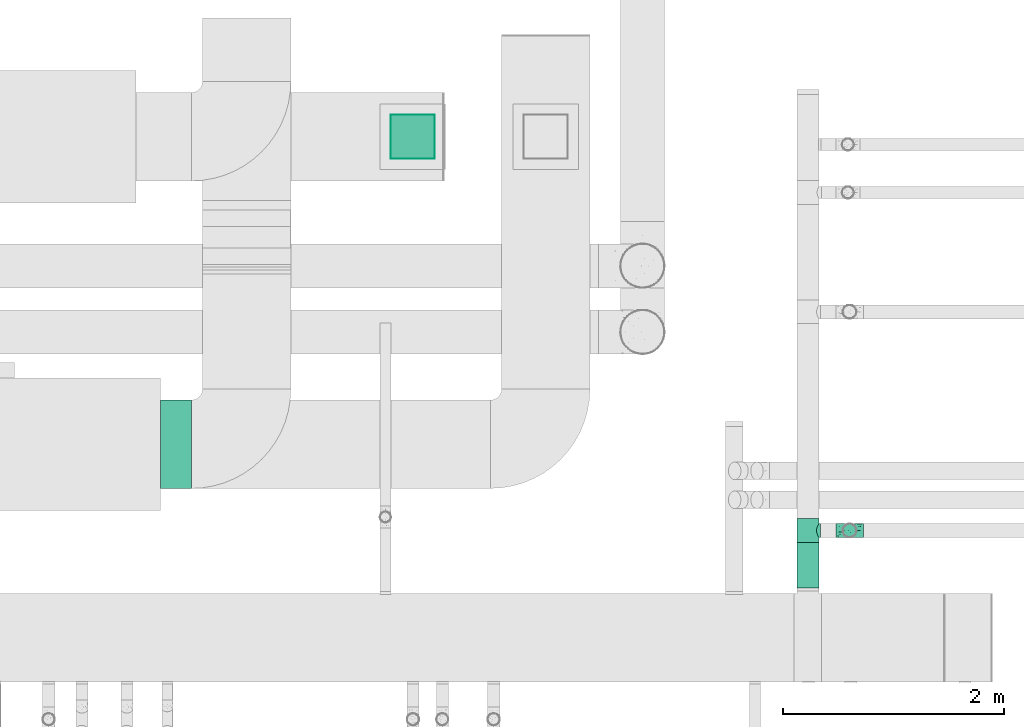
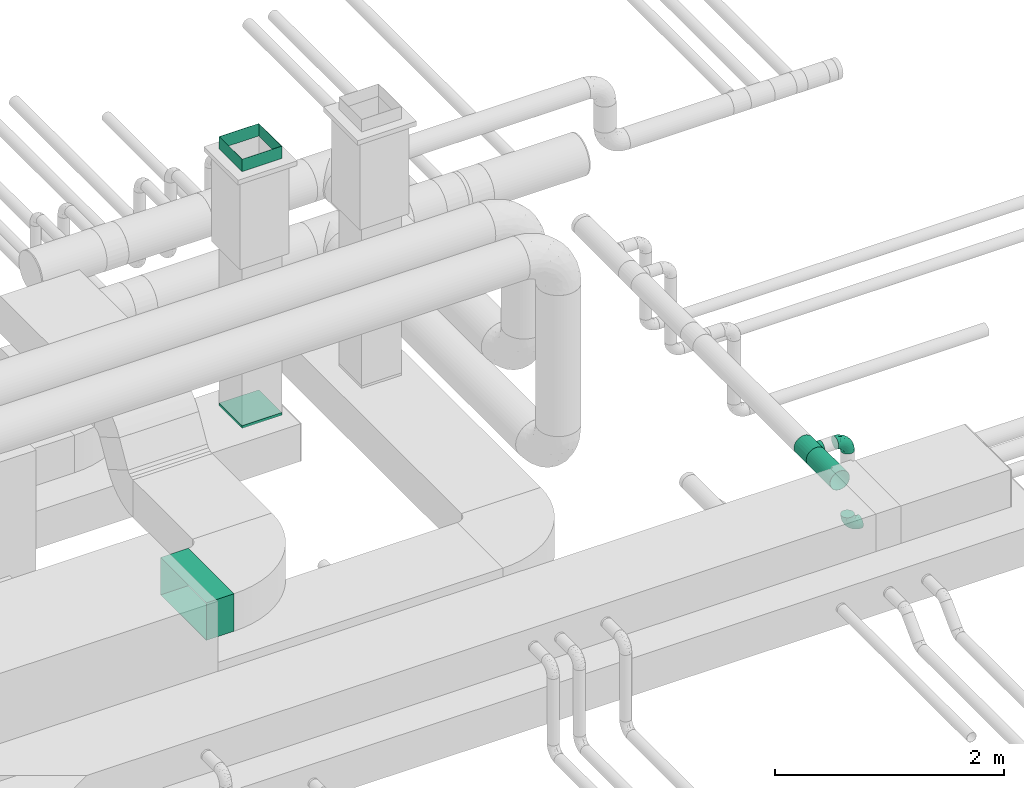
# One storey, part 63 of 91: 4 flow fittings, 3 flow segments.
"""IFC2X3 building model written with IfcOpenShell, lengths in millimetres."""

from ifc_helpers import new_model, entity, si_unit, converted_unit, derived_unit, direction, frame, origin_with_axes, origin_2d_with_axis, place, context, subcontext, project, spatial, hollow_rectangle, hollow_circle, extrude, open_shell, surface_model, source, transform, mapped, material, layer, layer_set, layer_usage, type_object, element, save


model = new_model("IFC2X3")

# Units and contexts
model_context = context("Model", 3, precision=1e-05, world=origin_with_axes(), true_north=direction((0.0, 1.0)))
body_context = subcontext(model_context, "Body", "Model", "MODEL_VIEW")
ifc_project = project(units=[si_unit("AREAUNIT", "SQUARE_METRE"), si_unit("VOLUMEUNIT", "CUBIC_METRE", prefix="DECI"), si_unit("TIMEUNIT", "SECOND"), si_unit("THERMODYNAMICTEMPERATUREUNIT", "DEGREE_CELSIUS"), si_unit("PRESSUREUNIT", "PASCAL"), si_unit("MASSUNIT", "GRAM", prefix="KILO"), si_unit("LENGTHUNIT", "METRE", prefix="MILLI"), si_unit("POWERUNIT", "WATT"), si_unit("ELECTRICCURRENTUNIT", "AMPERE"), si_unit("ELECTRICVOLTAGEUNIT", "VOLT"), derived_unit("VOLUMETRICFLOWRATEUNIT", [(si_unit("VOLUMEUNIT", "CUBIC_METRE", prefix="DECI"), 1), (si_unit("TIMEUNIT", "SECOND"), -1)]), derived_unit("LINEARVELOCITYUNIT", [(si_unit("LENGTHUNIT", "METRE"), 1), (si_unit("TIMEUNIT", "SECOND"), -1)]), derived_unit("MASSDENSITYUNIT", [(si_unit("MASSUNIT", "GRAM", prefix="KILO"), 1), (si_unit("VOLUMEUNIT", "CUBIC_METRE"), -1)]), converted_unit("PLANEANGLEUNIT", "DEGREE", entity("IfcRatioMeasure", 0.01745), si_unit("PLANEANGLEUNIT", "RADIAN"), dimensions=[0, 0, 0, 0, 0, 0, 0])], contexts=[model_context])

# Site, building, storey
site_placement = place(None, origin_with_axes())
site = spatial("IfcSite", under=ifc_project, at=site_placement, CompositionType="ELEMENT")
building_placement = place(site_placement, origin_with_axes())
building = spatial("IfcBuilding", under=site, at=building_placement, Name="mc-building", CompositionType="ELEMENT")
storey_placement = place(building_placement, frame((0.0, 0.0, 8700.0), z_axis=(0.0, 0.0, 1.0), x_axis=(1.0, 0.0, 0.0)))
storey = spatial("IfcBuildingStorey", under=building, at=storey_placement, CompositionType="ELEMENT", Elevation=8700.0)

# Flow fittings
duct_fitting_type_1 = type_object("IfcDuctFittingType", PredefinedType="JUNCTION")
shared_shape_1 = source(origin_with_axes(), body_context, "Body", "SurfaceModel", [
    surface_model("IfcShellBasedSurfaceModel", [(0.0, -115.0, -62.5), (16.17619, -115.0, -60.37037), (-16.17619, -115.0, -60.37037), (-60.37037, -115.0, 16.17619), (-31.25, -115.0, -54.12659), (-44.19417, -115.0, -44.19417), (-54.12659, -115.0, -31.25), (62.5, -115.0, 0.0), (60.37037, -115.0, 16.17619), (44.19417, -115.0, -44.19417), (31.25, -115.0, -54.12659), (60.37037, -115.0, -16.17619), (54.12659, -115.0, -31.25), (-60.37037, -115.0, -16.17619), (-54.12659, -115.0, 31.25), (-44.19417, -115.0, 44.19417), (-31.25, -115.0, 54.12659), (-16.17619, -115.0, 60.37037), (16.17619, -115.0, 60.37037), (54.12659, -115.0, 31.25), (44.19417, -115.0, 44.19417), (31.25, -115.0, 54.12659), (0.0, -115.0, 62.5), (-62.5, -115.0, 0.0), (0.0, -78.06248, 62.5), (-12.50928, -79.05841, 61.23535), (-24.28343, -81.75228, 57.58963), (-34.88436, -85.50245, 51.85876), (-44.09526, -89.65568, 44.29287), (-51.73336, -93.64876, 35.07007), (-57.55016, -96.98335, 24.37682), (-61.23402, -99.21368, 12.5158), (-62.5, -100.0, 0.0), (-61.23126, -99.21198, -12.5293), (-57.54468, -96.9801, -24.38976), (-51.72588, -93.64463, -35.0811), (-44.08702, -89.65163, -44.30107), (-34.87655, -85.49926, -51.86401), (-24.27625, -81.75015, -57.59265), (-12.50125, -79.05714, -61.23699), (0.0, -78.06248, -62.5), (12.50928, -79.05841, -61.23535), (24.28343, -81.75228, -57.58963), (34.88436, -85.50245, -51.85876), (44.09526, -89.65568, -44.29287), (51.73336, -93.64876, -35.07007), (57.55016, -96.98335, -24.37682), (61.23402, -99.21368, -12.5158), (62.5, -100.0, 0.0), (61.23402, -99.21368, 12.5158), (57.55016, -96.98335, 24.37682), (51.73336, -93.64876, 35.07007), (44.09526, -89.65568, 44.29287), (34.88436, -85.50245, 51.85876), (24.28343, -81.75228, 57.58963), (12.50928, -79.05841, 61.23535), (-107.5, 0.0, -100.0), (-107.5, -25.8819, -96.59259), (-107.5, 25.8819, -96.59259), (-107.5, 96.59259, 25.8819), (-107.5, 50.0, -86.60254), (-107.5, 86.60254, -50.0), (-107.5, 70.71068, -70.71068), (-107.5, -100.0, 0.0), (-107.5, -96.59259, 25.8819), (-107.5, -70.71068, -70.71068), (-107.5, -50.0, -86.60254), (-107.5, -96.59259, -25.8819), (-107.5, -86.60254, -50.0), (-107.5, 96.59259, -25.8819), (-107.5, 86.60254, 50.0), (-107.5, 70.71068, 70.71068), (-107.5, 50.0, 86.60254), (-107.5, 25.8819, 96.59259), (-107.5, 0.0, 100.0), (-107.5, -86.60254, 50.0), (-107.5, -70.71068, 70.71068), (-107.5, -25.8819, 96.59259), (-107.5, -50.0, 86.60254), (-107.5, 100.0, 0.0), (107.5, 25.8819, -96.59259), (107.5, 100.0, 0.0), (107.5, 0.0, -100.0), (107.5, 50.0, -86.60254), (107.5, 70.71068, -70.71068), (107.5, 86.60254, -50.0), (107.5, -70.71068, -70.71068), (107.5, -96.59259, 25.8819), (107.5, -50.0, -86.60254), (107.5, -25.8819, -96.59259), (107.5, -86.60254, -50.0), (107.5, -96.59259, -25.8819), (107.5, -100.0, 0.0), (107.5, 96.59259, -25.8819), (107.5, 96.59259, 25.8819), (107.5, 86.60254, 50.0), (107.5, 70.71068, 70.71068), (107.5, 25.8819, 96.59259), (107.5, 50.0, 86.60254), (107.5, -25.8819, 96.59259), (107.5, -86.60254, 50.0), (107.5, -70.71068, 70.71068), (107.5, -50.0, 86.60254), (107.5, 0.0, 100.0), (107.5, -91.59756, -37.94095), (-107.5, -98.29629, -12.94095), (-107.5, -91.59756, -37.94095), (107.5, -98.29629, -12.94095), (107.5, -98.29629, 12.94095), (107.5, -91.59756, 37.94095), (-107.5, -98.29629, 12.94095), (-107.5, -91.59756, 37.94095)], [open_shell([[[0, 1, 2]], [[2, 3, 4]], [[5, 3, 6]], [[4, 3, 5]], [[2, 7, 8]], [[9, 7, 10]], [[1, 10, 7]], [[11, 7, 12]], [[9, 12, 7]], [[7, 2, 1]], [[13, 6, 3]], [[2, 14, 3]], [[2, 15, 14]], [[16, 2, 17]], [[16, 15, 2]], [[17, 2, 18]], [[19, 20, 2]], [[19, 2, 8]], [[20, 21, 2]], [[2, 21, 18]], [[18, 22, 17]], [[23, 13, 3]], [[22, 24, 25]], [[17, 25, 26]], [[16, 26, 27]], [[22, 25, 17]], [[15, 27, 28]], [[16, 17, 26]], [[27, 15, 16]], [[29, 30, 14]], [[31, 32, 23]], [[30, 31, 3]], [[15, 29, 14]], [[3, 14, 30]], [[23, 3, 31]], [[29, 15, 28]], [[32, 33, 23]], [[34, 35, 6]], [[33, 34, 13]], [[23, 33, 13]], [[6, 13, 34]], [[5, 6, 35]], [[35, 36, 5]], [[4, 37, 38]], [[38, 39, 2]], [[40, 0, 39]], [[37, 5, 36]], [[37, 4, 5]], [[4, 38, 2]], [[39, 0, 2]], [[0, 40, 41]], [[1, 41, 42]], [[10, 42, 43]], [[0, 41, 1]], [[9, 43, 44]], [[10, 1, 42]], [[43, 9, 10]], [[45, 46, 12]], [[47, 48, 7]], [[46, 47, 11]], [[9, 45, 12]], [[11, 12, 46]], [[7, 11, 47]], [[45, 9, 44]], [[48, 49, 7]], [[50, 51, 19]], [[49, 50, 8]], [[7, 49, 8]], [[19, 8, 50]], [[20, 19, 51]], [[51, 52, 20]], [[21, 53, 54]], [[54, 55, 18]], [[24, 22, 55]], [[53, 20, 52]], [[53, 21, 20]], [[21, 54, 18]], [[55, 22, 18]], [[56, 57, 58]], [[58, 59, 60]], [[61, 62, 59]], [[59, 62, 60]], [[58, 63, 64]], [[65, 63, 66]], [[58, 57, 66]], [[67, 63, 68]], [[65, 68, 63]], [[66, 63, 58]], [[69, 61, 59]], [[70, 59, 58]], [[58, 71, 70]], [[72, 58, 73]], [[72, 71, 58]], [[74, 73, 58]], [[75, 76, 58]], [[58, 64, 75]], [[77, 74, 78]], [[58, 76, 78]], [[78, 74, 58]], [[79, 69, 59]], [[80, 81, 82]], [[83, 81, 80]], [[81, 84, 85]], [[83, 84, 81]], [[86, 82, 87]], [[82, 88, 89]], [[82, 86, 88]], [[90, 87, 91]], [[87, 90, 86]], [[92, 91, 87]], [[93, 81, 85]], [[94, 95, 82]], [[95, 96, 82]], [[97, 82, 98]], [[82, 96, 98]], [[99, 82, 97]], [[82, 100, 87]], [[101, 100, 82]], [[101, 82, 102]], [[99, 102, 82]], [[97, 103, 99]], [[82, 81, 94]], [[73, 103, 97]], [[72, 97, 98]], [[74, 103, 73]], [[73, 97, 72]], [[98, 71, 72]], [[98, 96, 71]], [[59, 95, 94]], [[79, 94, 81]], [[96, 70, 71]], [[96, 95, 70]], [[70, 95, 59]], [[94, 79, 59]], [[93, 85, 61]], [[81, 93, 69]], [[69, 79, 81]], [[61, 69, 93]], [[85, 62, 61]], [[85, 84, 62]], [[58, 83, 80]], [[56, 80, 82]], [[84, 60, 62]], [[84, 83, 60]], [[60, 83, 58]], [[80, 56, 58]], [[89, 57, 82]], [[88, 66, 89]], [[42, 90, 43]], [[90, 42, 86]], [[44, 104, 45]], [[42, 41, 86]], [[88, 86, 65]], [[86, 41, 40]], [[57, 89, 66]], [[65, 66, 88]], [[57, 56, 82]], [[40, 39, 65]], [[33, 63, 105]], [[65, 38, 68]], [[35, 67, 106]], [[46, 107, 47]], [[39, 38, 65]], [[65, 86, 40]], [[68, 38, 37]], [[104, 91, 45]], [[44, 90, 104]], [[91, 46, 45]], [[92, 48, 47]], [[91, 107, 46]], [[47, 107, 92]], [[35, 106, 36]], [[68, 36, 106]], [[35, 34, 67]], [[68, 37, 36]], [[105, 67, 34]], [[32, 63, 33]], [[105, 34, 33]], [[43, 90, 44]], [[48, 92, 49]], [[108, 87, 50]], [[50, 87, 51]], [[50, 49, 108]], [[52, 51, 109]], [[109, 100, 52]], [[63, 31, 110]], [[63, 32, 31]], [[30, 64, 110]], [[28, 75, 111]], [[111, 64, 29]], [[75, 28, 27]], [[29, 64, 30]], [[53, 100, 54]], [[51, 87, 109]], [[101, 55, 54]], [[54, 100, 101]], [[30, 110, 31]], [[102, 99, 77]], [[78, 101, 102]], [[55, 101, 24]], [[74, 99, 103]], [[25, 24, 76]], [[49, 92, 108]], [[26, 76, 75]], [[25, 76, 26]], [[28, 111, 29]], [[24, 101, 76]], [[101, 78, 76]], [[77, 78, 102]], [[99, 74, 77]], [[26, 75, 27]], [[53, 52, 100]]])]),
])
flow_fitting_1_placement = place(storey_placement, frame((33364.76981, 4322.30408, 1344.0), z_axis=(0.0, 0.0, 1.0), x_axis=(0.0, 1.0, 0.0)))
element("IfcFlowFitting", 1, at=flow_fitting_1_placement, inside=storey, type_object=duct_fitting_type_1, context=body_context, shape_type="MappedRepresentation", body=[
    mapped(shared_shape_1, transform((0.0, 0.0, 0.0), scale=1.0)),
])
duct_fitting_type_2 = type_object("IfcDuctFittingType", Name="BU", PredefinedType="BEND")
shared_shape_2 = source(origin_with_axes(), body_context, "Body", "SurfaceModel", [
    surface_model("IfcShellBasedSurfaceModel", [(-125.0, 0.0, -62.5), (-125.0, -16.17619, -60.37037), (-125.0, 16.17619, -60.37037), (-125.0, 60.37037, 16.17619), (-125.0, 31.25, -54.12659), (-125.0, 54.12659, -31.25), (-125.0, 44.19417, -44.19417), (-125.0, -62.5, 0.0), (-125.0, -60.37037, 16.17619), (-125.0, -44.19417, -44.19417), (-125.0, -31.25, -54.12659), (-125.0, -60.37037, -16.17619), (-125.0, -54.12659, -31.25), (-125.0, 60.37037, -16.17619), (-125.0, 54.12659, 31.25), (-125.0, 44.19417, 44.19417), (-125.0, 16.17619, 60.37037), (-125.0, 31.25, 54.12659), (-125.0, -16.17619, 60.37037), (-125.0, -54.12659, 31.25), (-125.0, -44.19417, 44.19417), (-125.0, -31.25, 54.12659), (-125.0, 0.0, 62.5), (-125.0, 62.5, 0.0), (-16.17619, 125.0, -60.37037), (-62.5, 125.0, 0.0), (0.0, 125.0, -62.5), (-31.25, 125.0, -54.12659), (-44.19417, 125.0, -44.19417), (-54.12659, 125.0, -31.25), (44.19417, 125.0, -44.19417), (60.37037, 125.0, 16.17619), (31.25, 125.0, -54.12659), (16.17619, 125.0, -60.37037), (54.12659, 125.0, -31.25), (60.37037, 125.0, -16.17619), (62.5, 125.0, 0.0), (-60.37037, 125.0, -16.17619), (-60.37037, 125.0, 16.17619), (-54.12659, 125.0, 31.25), (-44.19417, 125.0, 44.19417), (-31.25, 125.0, 54.12659), (0.0, 125.0, 62.5), (-16.17619, 125.0, 60.37037), (54.12659, 125.0, 31.25), (44.19417, 125.0, 44.19417), (31.25, 125.0, 54.12659), (16.17619, 125.0, 60.37037), (-72.97423, 55.32904, 49.58459), (-87.09148, 43.38651, 51.77259), (-68.69218, 37.01083, 59.02974), (-86.37288, 6.11794, 62.5), (-102.44946, 13.57266, 61.46748), (-89.31796, 30.42505, 57.74247), (-79.75876, 21.08139, 61.40263), (-85.85709, 61.60432, 36.83247), (-105.99571, 52.01835, 38.04759), (-109.23107, 25.15527, 57.74247), (-23.87288, 51.52684, 62.5), (-20.86657, 80.09577, 61.41459), (-36.41116, 67.77294, 59.36871), (-72.59833, 84.97566, 20.44471), (-84.84527, 71.68644, 22.63776), (-72.28039, 75.08953, 34.06229), (-113.17841, 59.9112, 21.05599), (-105.80839, 64.31191, 11.93589), (-111.60883, 65.16367, 0.0), (-60.71426, 105.22832, 23.91771), (-100.62332, 62.31546, 23.91771), (-13.4791, 102.54506, 61.48083), (-6.11794, 86.37288, 62.5), (-65.16367, 111.60883, 0.0), (-64.37068, 105.82697, 11.61464), (-51.52684, 23.87288, 62.5), (-50.69134, 50.69135, 59.24335), (-105.32369, 40.3031, 49.58458), (-25.28712, 108.41778, 57.74247), (-40.88389, 102.97269, 49.58458), (-49.66967, 79.07581, 50.53579), (-30.95126, 87.95323, 57.74247), (-65.09409, 90.12761, 28.38341), (-66.67939, 95.80824, 18.23245), (-94.24179, 68.59274, 14.67936), (-56.68565, 61.95245, 53.66363), (-84.74719, 75.95181, 10.86071), (-51.54332, 107.92365, 38.04759), (-67.25753, 101.08228, 0.0), (-58.54205, 89.35136, 38.04759), (-74.03168, 90.94406, 0.0), (-64.15138, 70.52814, 45.04029), (-101.08228, 67.25753, 0.0), (-80.80582, 80.80582, 0.0), (-90.94406, 74.03168, 0.0), (-107.87602, 51.55441, -38.04759), (-105.81087, 64.31979, -11.89334), (-113.23859, 59.9943, -20.79563), (-102.50484, 41.0078, -49.58458), (-90.90834, 52.91787, -43.09941), (-86.37288, 6.11794, -62.5), (-82.6746, 22.37103, -60.91508), (-51.52684, 23.87288, -62.5), (-24.90859, 74.00088, -61.20337), (-6.11794, 86.37288, -62.5), (-23.87288, 51.52684, -62.5), (-40.24859, 105.55983, -49.58458), (-103.52624, 12.53143, -61.61172), (-52.01835, 105.9957, -38.04759), (-102.84629, 26.37525, -57.74247), (-80.60061, 37.86129, -56.26993), (-89.23788, 71.99576, -13.34087), (-28.31259, 95.51825, -57.74247), (-100.89706, 62.20969, -23.91771), (-79.09001, 65.16893, -38.04759), (-83.36843, 70.98492, -26.07025), (-72.14843, 76.80808, -32.35146), (-64.31191, 105.80839, -11.93589), (-62.31546, 100.62332, -23.91771), (-61.48499, 86.19979, -36.72576), (-65.63586, 35.3365, -60.01002), (-59.9112, 113.17841, -21.05599), (-14.35128, 101.66255, -61.35337), (-39.16846, 75.52412, -56.86737), (-49.98148, 49.98148, -59.57135), (-74.75599, 82.48123, -20.09995), (-79.93714, 49.60562, -50.24944), (-65.30683, 59.08485, -51.03937), (-69.00621, 93.51335, -14.6428), (-48.12403, 84.36987, -49.58459), (-65.05902, 72.16091, -43.27513), (-91.99255, 60.8749, -33.31849), (-74.30538, -22.05025, -54.52849), (-83.27732, -57.79898, 0.0), (-93.43528, -58.70511, -11.68929), (-65.26967, -50.32842, -16.71444), (20.96007, 31.53005, -39.63719), (36.17209, 58.4237, -38.31102), (29.66468, 29.66696, -26.32537), (-59.46467, 5.17337, -61.41841), (9.88584, 35.44281, -50.43749), (-6.21876, 6.21876, -45.37394), (1.26602, -1.26602, -32.1996), (5.97284, -5.97284, -16.71444), (-29.66696, -29.66468, -26.32537), (-5.17337, 59.46467, -61.41841), (-25.56296, 25.56296, -60.51531), (-85.76554, -12.75621, -59.78088), (48.55289, 56.98302, -11.64673), (57.71969, 88.32124, -11.85826), (57.79898, 83.27732, 0.0), (-8.09566, -21.5934, 0.0), (-43.6468, -43.93166, 0.0), (-26.3245, -32.97333, -12.3928), (-83.98915, -46.13442, -36.15679), (-66.40639, -30.82245, -46.75569), (-31.53004, -20.96006, -39.63719), (-52.51367, -36.89027, -34.10077), (12.75621, 85.76554, -59.78088), (4.48155, 49.92421, -57.42403), (37.53998, 99.49287, -48.41169), (22.05025, 74.30538, -54.52849), (-15.22434, 15.22435, -54.69384), (-49.9242, -4.48154, -57.42403), (51.83554, 76.17092, -22.12398), (46.66757, 86.70304, -36.28653), (-35.4428, -9.88583, -50.43749), (21.5934, 8.09566, 0.0), (43.93166, 43.6468, 0.0), (32.97333, 26.3245, -12.3928), (-99.49287, -37.53998, -48.41169), (30.82245, 66.40639, -46.75569), (-56.98302, -48.55289, 11.64673), (-88.32124, -57.71969, 11.85826), (50.32842, 65.26967, 16.71444), (-76.17092, -51.83554, 22.12398), (-5.17337, 59.46467, 61.41841), (12.75621, 85.76554, 59.78088), (-85.76554, -12.75621, 59.78088), (-49.9242, -4.48154, 57.42403), (-59.46467, 5.17337, 61.41841), (-26.3245, -32.97333, 12.3928), (-35.4428, -9.88583, 50.43749), (-31.53004, -20.96006, 39.63719), (-6.21876, 6.21876, 45.37394), (32.97333, 26.3245, 12.3928), (5.97284, -5.97284, 16.71444), (-99.49287, -37.53998, 48.41169), (-86.70304, -46.66757, 36.28653), (9.88584, 35.44281, 50.43749), (20.96007, 31.53005, 39.63719), (-15.22434, 15.22435, 54.69384), (4.48155, 49.92421, 57.42403), (-74.30538, -22.05025, 54.52849), (-25.56296, 25.56296, 60.51531), (37.53998, 99.49287, 48.41169), (46.13442, 83.98915, 36.15679), (29.66468, 29.66696, 26.32537), (-29.66696, -29.66468, 26.32537), (1.26602, -1.26602, 32.1996), (58.70511, 93.43528, 11.68929), (30.82245, 66.40639, 46.75569), (36.89027, 52.51367, 34.10076), (22.05025, 74.30538, 54.52849), (-58.42369, -36.17209, 38.31102), (-66.40639, -30.82245, 46.75569)], [open_shell([[[0, 1, 2]], [[2, 3, 4]], [[5, 6, 3]], [[4, 3, 6]], [[2, 7, 8]], [[9, 7, 10]], [[1, 10, 7]], [[11, 7, 12]], [[9, 12, 7]], [[7, 2, 1]], [[5, 3, 13]], [[14, 3, 2]], [[15, 14, 2]], [[2, 16, 17]], [[17, 15, 2]], [[2, 18, 16]], [[2, 8, 19]], [[2, 19, 20]], [[20, 21, 2]], [[18, 2, 21]], [[18, 22, 16]], [[23, 13, 3]], [[24, 25, 26]], [[27, 25, 24]], [[25, 28, 29]], [[28, 25, 27]], [[30, 26, 31]], [[26, 32, 33]], [[26, 30, 32]], [[30, 31, 34]], [[34, 31, 35]], [[31, 36, 35]], [[29, 37, 25]], [[38, 39, 26]], [[39, 40, 26]], [[26, 41, 42]], [[41, 26, 40]], [[41, 43, 42]], [[44, 31, 26]], [[45, 44, 26]], [[26, 46, 45]], [[47, 46, 26]], [[47, 26, 42]], [[25, 38, 26]], [[48, 49, 50]], [[22, 51, 52]], [[53, 54, 50]], [[55, 56, 49]], [[56, 14, 15]], [[16, 57, 17]], [[58, 59, 60]], [[61, 62, 63]], [[3, 64, 65]], [[53, 52, 54]], [[3, 65, 66]], [[67, 39, 38]], [[56, 68, 64]], [[65, 64, 68]], [[69, 59, 70]], [[38, 71, 72]], [[73, 58, 74]], [[75, 49, 56]], [[76, 69, 43]], [[53, 57, 52]], [[77, 78, 79]], [[41, 76, 43]], [[43, 69, 42]], [[55, 68, 56]], [[15, 17, 75]], [[76, 77, 79]], [[80, 67, 81]], [[62, 82, 68]], [[60, 78, 83]], [[62, 84, 82]], [[85, 77, 40]], [[81, 67, 72]], [[86, 72, 71]], [[87, 85, 67]], [[61, 81, 88]], [[77, 41, 40]], [[78, 77, 87]], [[15, 75, 56]], [[83, 89, 48]], [[85, 40, 39]], [[62, 68, 55]], [[89, 87, 63]], [[83, 48, 50]], [[57, 75, 17]], [[49, 75, 53]], [[67, 85, 39]], [[87, 77, 85]], [[63, 62, 55]], [[89, 55, 48]], [[80, 63, 87]], [[66, 65, 90]], [[66, 23, 3]], [[84, 91, 92]], [[92, 90, 82]], [[65, 82, 90]], [[61, 84, 62]], [[92, 82, 84]], [[68, 82, 65]], [[3, 14, 64]], [[56, 64, 14]], [[38, 25, 71]], [[81, 72, 86]], [[38, 72, 67]], [[91, 61, 88]], [[80, 81, 61]], [[63, 80, 61]], [[67, 80, 87]], [[77, 76, 41]], [[79, 59, 69]], [[79, 69, 76]], [[42, 69, 70]], [[60, 59, 79]], [[58, 70, 59]], [[78, 60, 79]], [[58, 60, 74]], [[52, 57, 16]], [[75, 57, 53]], [[22, 52, 16]], [[52, 51, 54]], [[51, 73, 54]], [[50, 73, 74]], [[73, 50, 54]], [[50, 74, 83]], [[60, 83, 74]], [[89, 83, 78]], [[87, 89, 78]], [[55, 89, 63]], [[50, 49, 53]], [[55, 49, 48]], [[81, 86, 88]], [[91, 84, 61]], [[6, 5, 93]], [[90, 94, 66]], [[13, 94, 95]], [[96, 93, 97]], [[98, 99, 100]], [[96, 4, 6]], [[101, 102, 103]], [[28, 27, 104]], [[2, 105, 0]], [[104, 106, 28]], [[99, 105, 107]], [[108, 107, 96]], [[90, 109, 94]], [[107, 2, 4]], [[13, 66, 94]], [[27, 24, 110]], [[109, 111, 94]], [[112, 113, 114]], [[37, 115, 71]], [[116, 106, 117]], [[99, 118, 100]], [[116, 115, 119]], [[37, 119, 115]], [[24, 120, 110]], [[121, 110, 101]], [[119, 106, 116]], [[101, 110, 120]], [[122, 103, 100]], [[117, 123, 116]], [[124, 125, 108]], [[115, 116, 126]], [[106, 29, 28]], [[26, 102, 120]], [[127, 104, 110]], [[97, 124, 96]], [[125, 122, 118]], [[128, 127, 125]], [[96, 6, 93]], [[115, 126, 86]], [[117, 106, 127]], [[111, 113, 129]], [[95, 93, 5]], [[97, 129, 112]], [[110, 104, 27]], [[106, 104, 127]], [[96, 107, 4]], [[99, 107, 108]], [[99, 108, 118]], [[105, 99, 98]], [[112, 114, 128]], [[121, 125, 127]], [[13, 23, 66]], [[109, 90, 92]], [[94, 111, 95]], [[91, 123, 109]], [[129, 113, 112]], [[93, 95, 111]], [[5, 13, 95]], [[71, 115, 86]], [[71, 25, 37]], [[123, 91, 88]], [[126, 116, 123]], [[123, 88, 126]], [[86, 126, 88]], [[37, 29, 119]], [[106, 119, 29]], [[129, 93, 111]], [[124, 112, 125]], [[0, 105, 98]], [[107, 105, 2]], [[125, 118, 108]], [[100, 118, 122]], [[93, 129, 97]], [[113, 111, 109]], [[109, 123, 113]], [[114, 123, 117]], [[123, 114, 113]], [[128, 114, 117]], [[127, 128, 117]], [[112, 128, 125]], [[103, 122, 101]], [[110, 121, 127]], [[101, 122, 121]], [[125, 121, 122]], [[26, 120, 24]], [[101, 120, 102]], [[96, 124, 108]], [[92, 91, 109]], [[112, 124, 97]], [[10, 1, 130]], [[131, 132, 133]], [[134, 135, 136]], [[98, 100, 137]], [[138, 134, 139]], [[140, 141, 142]], [[143, 144, 103]], [[98, 145, 0]], [[146, 147, 148]], [[149, 150, 151]], [[7, 11, 132]], [[133, 12, 152]], [[153, 154, 155]], [[152, 12, 9]], [[156, 157, 143]], [[142, 151, 133]], [[155, 133, 152]], [[158, 159, 32]], [[136, 141, 140]], [[137, 145, 98]], [[103, 144, 100]], [[133, 132, 12]], [[160, 161, 144]], [[137, 144, 161]], [[160, 144, 157]], [[156, 26, 33]], [[130, 1, 145]], [[34, 162, 163]], [[164, 139, 154]], [[30, 158, 32]], [[160, 138, 139]], [[163, 30, 34]], [[156, 159, 157]], [[149, 141, 165]], [[146, 166, 167]], [[168, 9, 10]], [[36, 148, 147]], [[9, 168, 152]], [[150, 131, 133]], [[166, 146, 148]], [[166, 165, 167]], [[141, 136, 167]], [[160, 164, 161]], [[143, 103, 102]], [[151, 141, 149]], [[35, 162, 34]], [[135, 162, 136]], [[158, 163, 169]], [[144, 137, 100]], [[145, 137, 161]], [[145, 161, 130]], [[145, 1, 0]], [[102, 26, 156]], [[144, 143, 157]], [[102, 156, 143]], [[159, 33, 32]], [[141, 167, 165]], [[146, 136, 162]], [[133, 151, 150]], [[141, 151, 142]], [[164, 130, 161]], [[130, 153, 168]], [[159, 156, 33]], [[138, 159, 169]], [[138, 160, 157]], [[164, 160, 139]], [[154, 140, 142]], [[134, 140, 139]], [[159, 138, 157]], [[134, 136, 140]], [[138, 169, 134]], [[135, 134, 169]], [[139, 140, 154]], [[130, 164, 153]], [[155, 154, 142]], [[153, 164, 154]], [[136, 146, 167]], [[146, 162, 147]], [[162, 35, 147]], [[36, 147, 35]], [[130, 168, 10]], [[152, 168, 153]], [[163, 158, 30]], [[159, 158, 169]], [[7, 132, 131]], [[12, 132, 11]], [[169, 163, 135]], [[135, 163, 162]], [[133, 155, 142]], [[153, 155, 152]], [[150, 170, 131]], [[171, 7, 131]], [[166, 148, 172]], [[8, 173, 19]], [[174, 175, 70]], [[176, 177, 178]], [[149, 179, 150]], [[170, 150, 179]], [[180, 181, 182]], [[165, 183, 184]], [[20, 185, 21]], [[20, 19, 186]], [[187, 182, 188]], [[189, 187, 190]], [[185, 191, 21]], [[22, 18, 176]], [[190, 192, 189]], [[189, 180, 182]], [[178, 73, 51]], [[19, 173, 186]], [[149, 165, 184]], [[45, 193, 194]], [[191, 177, 176]], [[165, 166, 183]], [[195, 183, 172]], [[196, 184, 197]], [[194, 44, 45]], [[198, 36, 31]], [[199, 188, 200]], [[172, 198, 44]], [[193, 45, 46]], [[194, 200, 172]], [[175, 42, 70]], [[192, 58, 73]], [[170, 171, 131]], [[189, 192, 177]], [[70, 58, 174]], [[190, 174, 192]], [[179, 184, 196]], [[197, 184, 195]], [[47, 201, 46]], [[181, 202, 196]], [[148, 198, 172]], [[201, 47, 175]], [[172, 44, 194]], [[178, 192, 73]], [[202, 173, 196]], [[185, 186, 203]], [[192, 174, 58]], [[175, 174, 190]], [[175, 190, 201]], [[175, 47, 42]], [[51, 22, 176]], [[192, 178, 177]], [[51, 176, 178]], [[191, 18, 21]], [[184, 179, 149]], [[170, 196, 173]], [[172, 183, 166]], [[184, 183, 195]], [[187, 201, 190]], [[201, 199, 193]], [[191, 176, 18]], [[180, 191, 203]], [[180, 189, 177]], [[187, 189, 182]], [[188, 197, 195]], [[181, 197, 182]], [[191, 180, 177]], [[181, 196, 197]], [[180, 203, 181]], [[202, 181, 203]], [[182, 197, 188]], [[201, 187, 199]], [[200, 188, 195]], [[199, 187, 188]], [[196, 170, 179]], [[170, 173, 171]], [[173, 8, 171]], [[7, 171, 8]], [[201, 193, 46]], [[194, 193, 199]], [[186, 185, 20]], [[191, 185, 203]], [[36, 198, 148]], [[44, 198, 31]], [[203, 186, 202]], [[202, 186, 173]], [[172, 200, 195]], [[199, 200, 194]]])]),
])
for number, where, z_axis, x_axis, name in (
    (2, (33742.76981, 4322.30408, 1344.0), (0.0, -1.0, 0.0), (0.0, 0.0, 1.0), "BU"),
    (3, (33742.76981, 4322.30408, 415.0), (0.0, 1.0, 0.0), (-1.0, 0.0, 0.0), "BU"),
):
    element("IfcFlowFitting", number, at=place(storey_placement, frame(where, z_axis=z_axis, x_axis=x_axis)), inside=storey, type_object=duct_fitting_type_2, Name=name, context=body_context, shape_type="MappedRepresentation", body=[
        mapped(shared_shape_2, transform((0.0, 0.0, 0.0), scale=1.0)),
    ])

# Flow segments
ifc_material_1 = material(Name="1")
ifc_layer_1 = layer(ifc_material_1, 0.0)
ifc_layer_set_1 = layer_set([ifc_layer_1], Name="1")
ifc_layer_usage_1 = layer_usage(ifc_layer_set_1, "AXIS1", "POSITIVE", 0.0)
duct_segment_type_1 = type_object("IfcDuctSegmentType", PredefinedType="RIGIDSEGMENT")
shared_shape_3 = source(origin_with_axes(), body_context, "Body", "SweptSolid", [
    extrude(hollow_rectangle(XDim=800.0, YDim=400.0, WallThickness=2.0, at=origin_2d_with_axis()), frame((0.0, 0.0, 0.0), z_axis=(1.0, 0.0, 0.0), x_axis=(0.0, 1.0, 0.0)), (0.0, 0.0, 1.0), 279.9),
])
flow_segment_1_placement = place(storey_placement, frame((27500.0, 5104.45799, 1344.0), z_axis=(0.0, 0.0, 1.0), x_axis=(1.0, 0.0, 0.0)))
element("IfcFlowSegment", 4, at=flow_segment_1_placement, inside=storey, type_object=duct_segment_type_1, material=ifc_layer_usage_1, context=body_context, shape_type="MappedRepresentation", body=[
    mapped(shared_shape_3, transform((0.0, 0.0, 0.0), scale=1.0)),
])
ifc_material_2 = material(Name="FZ1")
ifc_layer_2 = layer(ifc_material_2, 0.0)
ifc_layer_set_2 = layer_set([ifc_layer_2], Name="FZ1")
ifc_layer_usage_2 = layer_usage(ifc_layer_set_2, "AXIS1", "POSITIVE", 0.0)
duct_segment_type_2 = type_object("IfcDuctSegmentType", Name="Safe", PredefinedType="RIGIDSEGMENT")
shared_shape_4 = source(origin_with_axes(), body_context, "Body", "SweptSolid", [
    extrude(hollow_circle(Radius=100.0, WallThickness=2.0, at=origin_2d_with_axis()), frame((0.0, 0.0, 0.0), z_axis=(1.0, 0.0, 0.0), x_axis=(0.0, 1.0, 0.0)), (0.0, 0.0, 1.0), 413.6),
])
flow_segment_2_placement = place(storey_placement, frame((33364.76981, 4214.80408, 1344.0), z_axis=(0.0, 0.0, 1.0), x_axis=(0.0, -1.0, 0.0)))
element("IfcFlowSegment", 5, at=flow_segment_2_placement, inside=storey, type_object=duct_segment_type_2, material=ifc_layer_usage_2, Name="Safe", context=body_context, shape_type="MappedRepresentation", body=[
    mapped(shared_shape_4, transform((0.0, 0.0, 0.0), scale=1.0)),
])

# Flow fitting
duct_fitting_type_3 = type_object("IfcDuctFittingType", Name="RR", PredefinedType="CONNECTOR")
shared_shape_5 = source(origin_with_axes(), body_context, "Body", "SurfaceModel", [
    surface_model("IfcShellBasedSurfaceModel", [(-6.096, 200.0, -200.0), (-6.096, -200.0, -200.0), (-6.096, -200.0, 200.0), (-6.096, 200.0, 200.0), (25.0, -200.0, -200.0), (25.0, -200.0, 200.0), (25.0, 200.0, -200.0), (25.0, 200.0, 200.0)], [open_shell([[[0, 1, 2]], [[2, 3, 0]], [[4, 2, 1]], [[2, 4, 5]], [[6, 1, 0]], [[1, 6, 4]], [[6, 0, 3]], [[3, 7, 6]], [[7, 3, 2]], [[2, 5, 7]], [[7, 5, 4]], [[4, 6, 7]]])]),
])
flow_fitting_2_placement = place(storey_placement, frame((29783.84753, 7890.34565, 868.0), z_axis=(-1.0, 0.0, 0.0), x_axis=(0.0, 0.0, 1.0)))
element("IfcFlowFitting", 6, at=flow_fitting_2_placement, inside=storey, type_object=duct_fitting_type_3, Name="RR", context=body_context, shape_type="MappedRepresentation", body=[
    mapped(shared_shape_5, transform((0.0, 0.0, 0.0), scale=1.0)),
])

# Flow segment
shared_shape_6 = source(origin_with_axes(), body_context, "Body", "SweptSolid", [
    extrude(hollow_rectangle(XDim=400.0, YDim=400.0, WallThickness=2.0, at=origin_2d_with_axis()), frame((0.0, 0.0, 0.0), z_axis=(1.0, 0.0, 0.0), x_axis=(0.0, 1.0, 0.0)), (0.0, 0.0, 1.0), 132.0),
])
flow_segment_3_placement = place(storey_placement, frame((29783.84753, 7890.34565, 3600.0), z_axis=(1.0, 0.0, 0.0), x_axis=(0.0, 0.0, 1.0)))
element("IfcFlowSegment", 7, at=flow_segment_3_placement, inside=storey, type_object=duct_segment_type_1, material=ifc_layer_usage_1, context=body_context, shape_type="MappedRepresentation", body=[
    mapped(shared_shape_6, transform((0.0, 0.0, 0.0), scale=1.0)),
])

save(model, "model.ifc")
